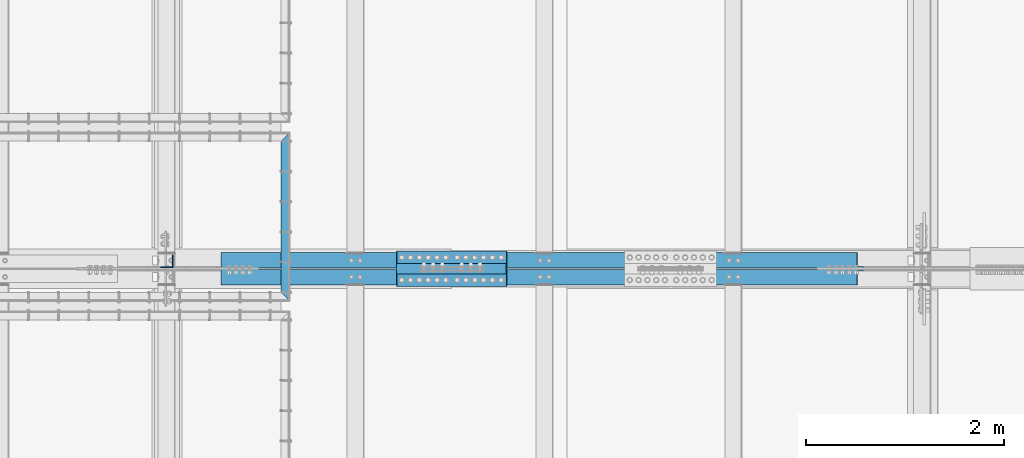
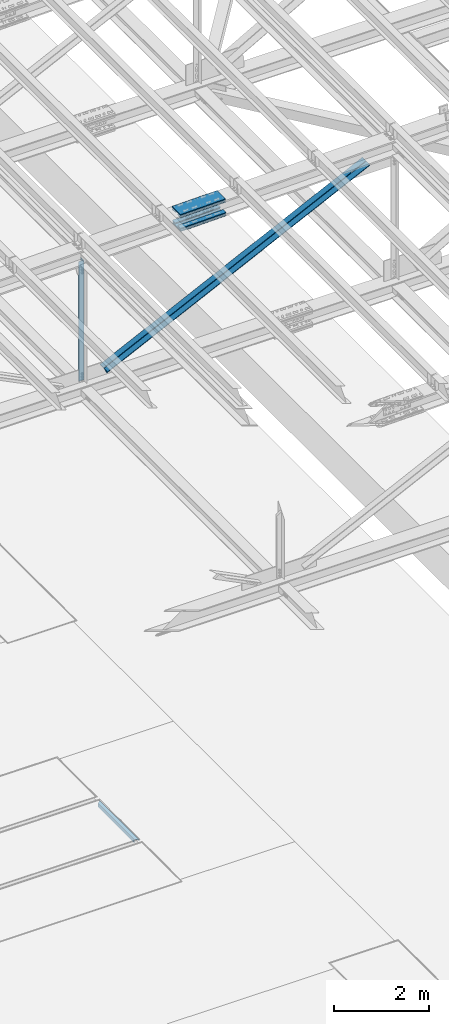
# One storey, part 1858 of 3843: 8 beams, 2 members, 5 elements without a shape of their own.
"""IFC2X3 building model written with IfcOpenShell, lengths in millimetres."""

from ifc_helpers import new_model, si_unit, frame, origin_with_axes, place, context, subcontext, project, spatial, faceted_brep, material, type_object, element, aggregate, save


model = new_model("IFC2X3")

# Units and contexts
model_context = context("Model", 3, precision=1e-05, world=origin_with_axes())
body_context = subcontext(model_context, "Body", "Model", "MODEL_VIEW")
ifc_project = project(units=[si_unit("LENGTHUNIT", "METRE", prefix="MILLI"), si_unit("AREAUNIT", "SQUARE_METRE"), si_unit("VOLUMEUNIT", "CUBIC_METRE"), si_unit("MASSUNIT", "GRAM", prefix="KILO"), si_unit("TIMEUNIT", "SECOND"), si_unit("PLANEANGLEUNIT", "RADIAN"), si_unit("SOLIDANGLEUNIT", "STERADIAN"), si_unit("THERMODYNAMICTEMPERATUREUNIT", "DEGREE_CELSIUS"), si_unit("LUMINOUSINTENSITYUNIT", "LUMEN")], contexts=[model_context])

# Site, building, storey
site_placement = place(None, origin_with_axes())
site = spatial("IfcSite", under=ifc_project, at=site_placement, CompositionType="ELEMENT")
building_placement = place(site_placement, origin_with_axes())
building = spatial("IfcBuilding", under=site, at=building_placement, Name="Undefined", CompositionType="ELEMENT")
storey_placement = place(building_placement, origin_with_axes())
storey = spatial("IfcBuildingStorey", under=building, at=storey_placement, Name="Undefined", CompositionType="ELEMENT", Elevation=0.0)

# Assembly, beam
assembly_1_placement = place(storey_placement, origin_with_axes())
assembly_1 = element("IfcElementAssembly", 1, at=assembly_1_placement, inside=storey, Name="EMBED_ANGLE", AssemblyPlace="NOTDEFINED", PredefinedType="RIGID_FRAME")
ifc_material_1 = material(Name="STEEL/A36")
beam_type_1 = type_object("IfcBeamType", Name="L3-1/2X3-1/2X5/16", PredefinedType="NOTDEFINED")
beam_1_placement = place(assembly_1_placement, frame((63830.962, 58587.8939999994, 30410.15), z_axis=(1.0, 0.0, 0.0), x_axis=(0.0, 1.0, 0.0)))
beam_1 = element("IfcBeam", 2, at=beam_1_placement, type_object=beam_type_1, material=ifc_material_1, Name="EMBED_ANGLE", ObjectType="L3-1/2X3-1/2X5/16", context=body_context, shape_type="Brep", body=[
    faceted_brep([(88.8999999971129, 44.4500000000007, -44.4499999999971), (-3.63797880709171e-12, 44.4499999999971, 44.4500000000007), (1702.18099999712, 44.4500000000007, 44.4499999999971), (1613.28099999713, 44.4500000000007, -44.4499999999971), (-3.63797880709171e-12, 36.5124999999971, 44.4500000000007), (1702.18099999712, 36.5125000000007, 44.4499999999971), (80.9624999971129, 36.5125000000007, -36.5124999999971), (1621.21849999713, 36.5125000000007, -36.5124999999971), (80.9624999971129, -44.4500000000007, -36.5124999999971), (1621.21849999713, -44.4500000000007, -36.5124999999971), (88.8999999971129, -44.4500000000007, -44.4499999999971), (1613.28099999713, -44.4500000000007, -44.4499999999971)], [[[0, 1, 2, 3]], [[1, 4, 5, 2]], [[4, 6, 7, 5]], [[6, 8, 9, 7]], [[8, 10, 11, 9]], [[10, 0, 3, 11]], [[5, 7, 9, 11, 3, 2]], [[10, 8, 6, 4, 1, 0]]]),
])
aggregate(assembly_1, [beam_1])

# Assembly, beams
assembly_2_placement = place(storey_placement, origin_with_axes())
assembly_2 = element("IfcElementAssembly", 3, at=assembly_2_placement, inside=storey, Name="BEAM", AssemblyPlace="NOTDEFINED", PredefinedType="RIGID_FRAME")
ifc_material_2 = material(Name="STEEL/A572-50")
beam_type_2 = type_object("IfcBeamType", PredefinedType="NOTDEFINED")
beam_2_placement = place(assembly_2_placement, frame((64955.3605150871, 59029.6, 46069.5397425675), z_axis=(0.0, -1.0, 0.0), x_axis=(0.999760896726764, 0.0, 0.021866626994028)))
beam_2 = element("IfcBeam", 4, at=beam_2_placement, type_object=beam_type_2, material=ifc_material_2, Name="PLATE", context=body_context, shape_type="Brep", body=[
    faceted_brep([(-4.36557456851006e-11, 12.7000000000116, -63.5), (-4.36557456851006e-11, 12.7000000000116, 63.5), (1104.90000001677, 12.7000000017251, 63.5), (1104.90000001677, 12.7000000017251, -63.5), (1.45519152283669e-11, -12.700000000008, 63.5), (1104.90000001682, -12.6999999982909, 63.5), (1.45519152283669e-11, -12.700000000008, -63.5), (1104.90000001682, -12.6999999982909, -63.5)], [[[0, 1, 2, 3]], [[1, 4, 5, 2]], [[4, 6, 7, 5]], [[6, 0, 3, 7]], [[5, 7, 3, 2]], [[6, 4, 1, 0]]]),
])
beam_3_placement = place(assembly_2_placement, frame((64961.8164651072, 59029.6, 45774.3681774078), z_axis=(0.0, -1.0, 0.0), x_axis=(0.999760896726764, 0.0, 0.021866626994028)))
beam_3 = element("IfcBeam", 5, at=beam_3_placement, type_object=beam_type_2, material=ifc_material_2, Name="PLATE", context=body_context, shape_type="Brep", body=[
    faceted_brep([(-4.36557456851006e-11, 12.7000000000116, -63.5), (-4.36557456851006e-11, 12.7000000000116, 63.5), (1104.90000001677, 12.7000000017251, 63.5), (1104.90000001677, 12.7000000017251, -63.5), (1.45519152283669e-11, -12.700000000008, 63.5), (1104.90000001682, -12.6999999982909, 63.5), (1.45519152283669e-11, -12.700000000008, -63.5), (1104.90000001682, -12.6999999982909, -63.5)], [[[0, 1, 2, 3]], [[1, 4, 5, 2]], [[4, 6, 7, 5]], [[6, 0, 3, 7]], [[5, 7, 3, 2]], [[6, 4, 1, 0]]]),
])
beam_4_placement = place(assembly_2_placement, frame((64955.3605150871, 58801.0, 46069.5397425675), z_axis=(0.0, -1.0, 0.0), x_axis=(0.999760896726764, 0.0, 0.021866626994028)))
beam_4 = element("IfcBeam", 6, at=beam_4_placement, type_object=beam_type_2, material=ifc_material_2, Name="PLATE", context=body_context, shape_type="Brep", body=[
    faceted_brep([(-4.36557456851006e-11, 12.7000000000116, -63.5), (-4.36557456851006e-11, 12.7000000000116, 63.5), (1104.90000001677, 12.7000000017251, 63.5), (1104.90000001677, 12.7000000017251, -63.5), (1.45519152283669e-11, -12.700000000008, 63.5), (1104.90000001682, -12.6999999982909, 63.5), (1.45519152283669e-11, -12.700000000008, -63.5), (1104.90000001682, -12.6999999982909, -63.5)], [[[0, 1, 2, 3]], [[1, 4, 5, 2]], [[4, 6, 7, 5]], [[6, 0, 3, 7]], [[5, 7, 3, 2]], [[6, 4, 1, 0]]]),
])
beam_5_placement = place(assembly_2_placement, frame((64961.8164651072, 58801.0, 45774.3681774078), z_axis=(0.0, -1.0, 0.0), x_axis=(0.999760896726764, 0.0, 0.021866626994028)))
beam_5 = element("IfcBeam", 7, at=beam_5_placement, type_object=beam_type_2, material=ifc_material_2, Name="PLATE", context=body_context, shape_type="Brep", body=[
    faceted_brep([(-4.36557456851006e-11, 12.7000000000116, -63.5), (-4.36557456851006e-11, 12.7000000000116, 63.5), (1104.90000001677, 12.7000000017251, 63.5), (1104.90000001677, 12.7000000017251, -63.5), (1.45519152283669e-11, -12.700000000008, 63.5), (1104.90000001682, -12.6999999982909, 63.5), (1.45519152283669e-11, -12.700000000008, -63.5), (1104.90000001682, -12.6999999982909, -63.5)], [[[0, 1, 2, 3]], [[1, 4, 5, 2]], [[4, 6, 7, 5]], [[6, 0, 3, 7]], [[5, 7, 3, 2]], [[6, 4, 1, 0]]]),
])
beam_type_3 = type_object("IfcBeamType", PredefinedType="NOTDEFINED")
beam_6_placement = place(assembly_2_placement, frame((66058.6402125293, 58915.3, 46155.703026438), z_axis=(0.0, -1.0, 0.0), x_axis=(-0.999760896726764, 0.0, -0.0218666269940254)))
beam_6 = element("IfcBeam", 8, at=beam_6_placement, type_object=beam_type_3, material=ifc_material_2, Name="PLATE", context=body_context, shape_type="Brep", body=[
    faceted_brep([(-1.45519152283669e-11, 12.7000000000025, -177.800000000003), (-1.45519152283669e-11, 12.7000000000025, 177.800000000003), (1104.90000001682, 12.7000000017051, 177.800000000003), (1104.90000001682, 12.7000000017051, -177.800000000003), (4.36557456851006e-11, -12.7000000000171, 177.800000000003), (1104.90000001686, -12.6999999983072, 177.800000000003), (4.36557456851006e-11, -12.7000000000171, -177.800000000003), (1104.90000001686, -12.6999999983072, -177.800000000003)], [[[0, 1, 2, 3]], [[1, 4, 5, 2]], [[4, 6, 7, 5]], [[6, 0, 3, 7]], [[5, 7, 3, 2]], [[6, 4, 1, 0]]]),
])
beam_7_placement = place(assembly_2_placement, frame((66067.8140541446, 58915.3, 45736.5982398618), z_axis=(0.0, -1.0, 0.0), x_axis=(-0.999760896726764, 0.0, -0.0218666269940254)))
beam_7 = element("IfcBeam", 9, at=beam_7_placement, type_object=beam_type_3, material=ifc_material_2, Name="PLATE", context=body_context, shape_type="Brep", body=[
    faceted_brep([(-1.45519152283669e-11, 12.7000000000025, -177.800000000003), (-1.45519152283669e-11, 12.7000000000025, 177.800000000003), (1104.90000001682, 12.7000000017051, 177.800000000003), (1104.90000001682, 12.7000000017051, -177.800000000003), (4.36557456851006e-11, -12.7000000000171, 177.800000000003), (1104.90000001686, -12.6999999983072, 177.800000000003), (4.36557456851006e-11, -12.7000000000171, -177.800000000003), (1104.90000001686, -12.6999999983072, -177.800000000003)], [[[0, 1, 2, 3]], [[1, 4, 5, 2]], [[4, 6, 7, 5]], [[6, 0, 3, 7]], [[5, 7, 3, 2]], [[6, 4, 1, 0]]]),
])
aggregate(assembly_2, [beam_2, beam_3, beam_4, beam_5, beam_6, beam_7])

# Assembly, beam
assembly_3_placement = place(storey_placement, origin_with_axes())
assembly_3 = element("IfcElementAssembly", 10, at=assembly_3_placement, inside=storey, Name="ANGLE", AssemblyPlace="NOTDEFINED", PredefinedType="RIGID_FRAME")
beam_type_4 = type_object("IfcBeamType", Name="L5X5X3/8", PredefinedType="NOTDEFINED")
beam_8_placement = place(assembly_3_placement, frame((62636.4, 58988.325, 45870.4545655945), z_axis=(-1.0, 0.0, 0.0), x_axis=(0.0, 0.0, -1.0)))
beam_8 = element("IfcBeam", 11, at=beam_8_placement, type_object=beam_type_4, material=ifc_material_2, Name="ANGLE", ObjectType="L5X5X3/8", context=body_context, shape_type="Brep", body=[
    faceted_brep([(223.717931562758, 63.5, -63.5), (223.717931562758, 63.5, 63.5), (3317.82975318309, 63.5, 63.5), (3317.82975318309, 63.5, -63.5), (223.717931562758, 53.9749999999985, 63.5), (3317.82975318309, 53.9749999999985, 63.5), (223.717931562758, 53.9749999999985, -53.9749999999985), (3317.82975318309, 53.9749999999985, -53.9749999999985), (223.717931562758, -63.5, -53.9749999999985), (3317.82975318309, -63.5, -53.9749999999985), (223.717931562758, -63.5, -63.5), (3317.82975318309, -63.5, -63.5)], [[[0, 1, 2, 3]], [[1, 4, 5, 2]], [[4, 6, 7, 5]], [[6, 8, 9, 7]], [[8, 10, 11, 9]], [[10, 0, 3, 11]], [[5, 7, 9, 11, 3, 2]], [[10, 8, 6, 4, 1, 0]]]),
])
aggregate(assembly_3, [beam_8])

# Assembly, member
assembly_4_placement = place(storey_placement, origin_with_axes())
assembly_4 = element("IfcElementAssembly", 12, at=assembly_4_placement, inside=storey, Name="ANGLE", AssemblyPlace="NOTDEFINED", PredefinedType="RIGID_FRAME")
member_type = type_object("IfcMemberType", Name="L6X6X1/2", PredefinedType="NOTDEFINED")
member_1_placement = place(assembly_4_placement, frame((70256.3999999752, 59001.025, 46035.6812855307), z_axis=(0.0, 1.0, 0.0), x_axis=(-0.89995161295068, 0.0, -0.435989786976105)))
member_1 = element("IfcMember", 13, at=member_1_placement, type_object=member_type, material=ifc_material_2, Name="ANGLE", ObjectType="L6X6X1/2", context=body_context, shape_type="Brep", body=[
    faceted_brep([(699.738125885211, 76.2000000032622, -76.1999999999971), (699.738125885211, 76.2000000032622, 76.1999999999971), (7824.91274311913, 76.2000000394928, 76.1999999999971), (7824.91274311913, 76.2000000394928, -76.1999999999971), (699.738125885153, 63.5000000033051, 76.1999999999971), (7824.9127431191, 63.5000000395503, 76.1999999999971), (699.738125885153, 63.5000000033051, -63.5), (7824.9127431191, 63.5000000395503, -63.5), (699.738125884716, -76.1999999961281, -63.5), (7824.91274311865, -76.1999999598975, -63.5), (699.738125884716, -76.1999999961281, -76.1999999999971), (7824.91274311865, -76.1999999598975, -76.1999999999971)], [[[0, 1, 2, 3]], [[1, 4, 5, 2]], [[4, 6, 7, 5]], [[6, 8, 9, 7]], [[8, 10, 11, 9]], [[10, 0, 3, 11]], [[5, 7, 9, 11, 3, 2]], [[10, 8, 6, 4, 1, 0]]]),
])
aggregate(assembly_4, [member_1])

assembly_5_placement = place(storey_placement, origin_with_axes())
assembly_5 = element("IfcElementAssembly", 14, at=assembly_5_placement, inside=storey, Name="ANGLE", AssemblyPlace="NOTDEFINED", PredefinedType="RIGID_FRAME")
member_2_placement = place(assembly_5_placement, frame((62636.3999981474, 58829.575, 42344.1026206927), z_axis=(0.0, -1.0, 0.0), x_axis=(0.89995161295068, 0.0, 0.435989786976105)))
member_2 = element("IfcMember", 15, at=member_2_placement, type_object=member_type, material=ifc_material_2, Name="ANGLE", ObjectType="L6X6X1/2", context=body_context, shape_type="Brep", body=[
    faceted_brep([(642.209144933237, 76.1999999984728, -76.1999999999971), (642.209144933237, 76.1999999984728, 76.1999999999971), (7767.38376207388, 76.199999984834, 76.1999999999971), (7767.38376207388, 76.199999984834, -76.1999999999971), (642.209144933237, 63.499999998523, 76.1999999999971), (7767.38376207386, 63.4999999848842, 76.1999999999971), (642.209144933237, 63.499999998523, -63.5), (7767.38376207386, 63.4999999848842, -63.5), (642.209144933237, -76.2000000009248, -63.5), (7767.38376207388, -76.2000000145526, -63.5), (642.209144933237, -76.2000000009248, -76.1999999999971), (7767.38376207388, -76.2000000145526, -76.1999999999971)], [[[0, 1, 2, 3]], [[1, 4, 5, 2]], [[4, 6, 7, 5]], [[6, 8, 9, 7]], [[8, 10, 11, 9]], [[10, 0, 3, 11]], [[5, 7, 9, 11, 3, 2]], [[10, 8, 6, 4, 1, 0]]]),
])
aggregate(assembly_5, [member_2])

save(model, "model.ifc")
